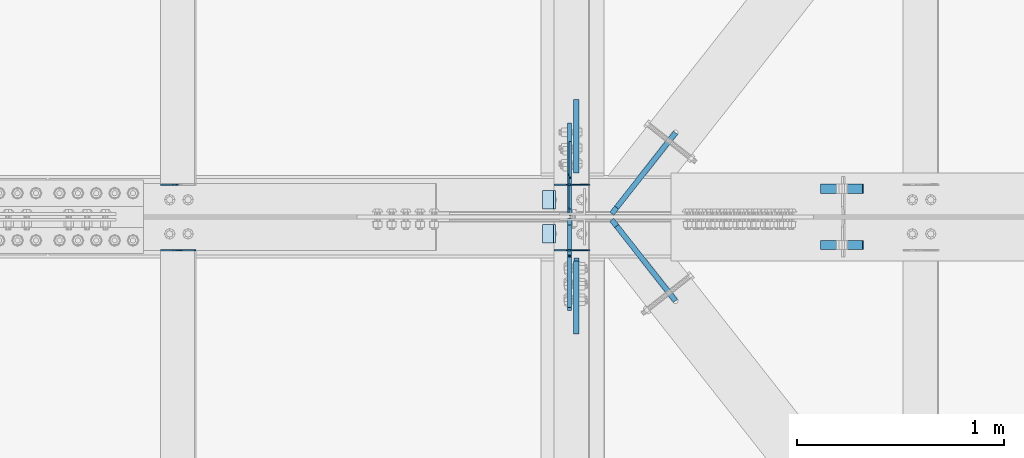
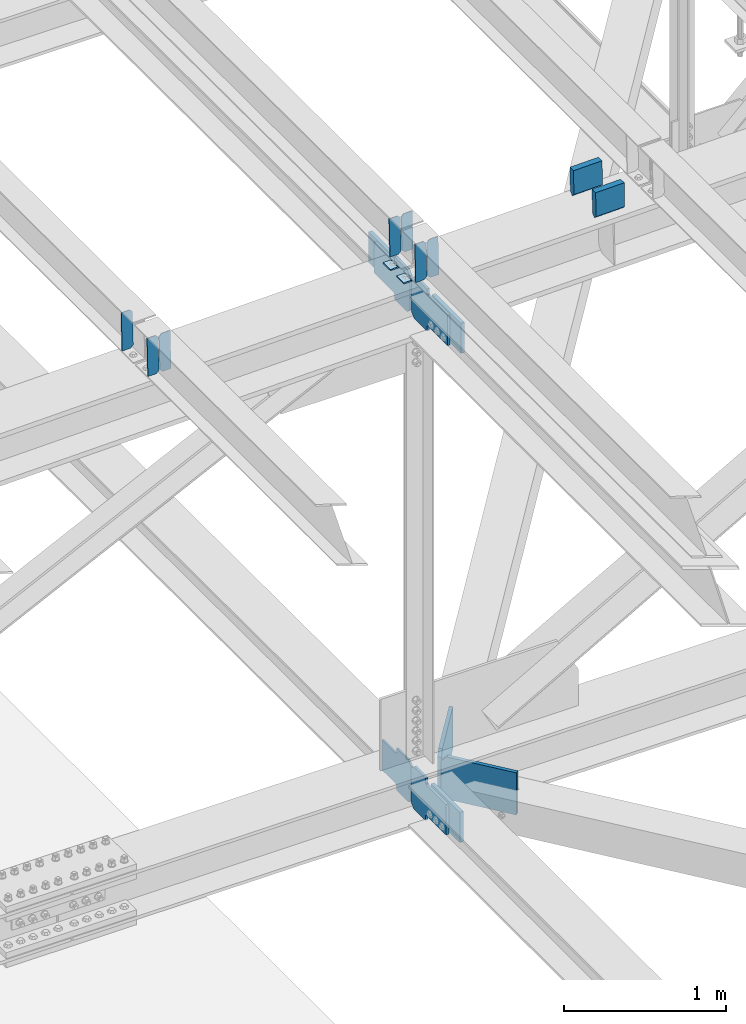
# One storey, part 3443 of 3843: 20 plates, 9 elements without a shape of their own.
"""IFC2X3 building model written with IfcOpenShell, lengths in millimetres."""

from ifc_helpers import new_model, si_unit, frame, origin_with_axes, place, context, subcontext, project, spatial, faceted_brep, material, type_object, element, aggregate, save


model = new_model("IFC2X3")

# Units and contexts
model_context = context("Model", 3, precision=1e-05, world=origin_with_axes())
body_context = subcontext(model_context, "Body", "Model", "MODEL_VIEW")
ifc_project = project(units=[si_unit("LENGTHUNIT", "METRE", prefix="MILLI"), si_unit("AREAUNIT", "SQUARE_METRE"), si_unit("VOLUMEUNIT", "CUBIC_METRE"), si_unit("MASSUNIT", "GRAM", prefix="KILO"), si_unit("TIMEUNIT", "SECOND"), si_unit("PLANEANGLEUNIT", "RADIAN"), si_unit("SOLIDANGLEUNIT", "STERADIAN"), si_unit("THERMODYNAMICTEMPERATUREUNIT", "DEGREE_CELSIUS"), si_unit("LUMINOUSINTENSITYUNIT", "LUMEN")], contexts=[model_context])

# Site, building, storey
site_placement = place(None, origin_with_axes())
site = spatial("IfcSite", under=ifc_project, at=site_placement, CompositionType="ELEMENT")
building_placement = place(site_placement, origin_with_axes())
building = spatial("IfcBuilding", under=site, at=building_placement, Name="Undefined", CompositionType="ELEMENT")
storey_placement = place(building_placement, origin_with_axes())
storey = spatial("IfcBuildingStorey", under=building, at=storey_placement, Name="Undefined", CompositionType="ELEMENT", Elevation=0.0)

# Assembly, plates
assembly_1_placement = place(storey_placement, origin_with_axes())
assembly_1 = element("IfcElementAssembly", 1, at=assembly_1_placement, inside=storey, Name="BEAM", AssemblyPlace="NOTDEFINED", PredefinedType="RIGID_FRAME")
ifc_material = material(Name="STEEL/A572-50")
plate_type_1 = type_object("IfcPlateType", PredefinedType="NOTDEFINED")
plate_1_placement = place(assembly_1_placement, frame((70338.6964783486, 67426.8505535728, 46241.0453819041), z_axis=(-0.0211520982737129, 0.00209111100100563, 0.999774082477337), x_axis=(-0.999776269341606, -4.42409999740035e-05, -0.0211520520071913)))
plate_1 = element("IfcPlate", 2, at=plate_1_placement, type_object=plate_type_1, material=ifc_material, Name="PLATE", context=body_context, shape_type="Brep", body=[
    faceted_brep([(0.0, -3.17499999999927, 0.0), (6.83940015733242e-10, -3.17499999996653, 288.924999998613), (6.54836185276508e-10, 3.17500000001746, 288.924999998591), (0.0, 3.17499999999927, 0.0), (60.3250007643655, -3.17500000017753, 288.924999998606), (60.3250007643219, 3.17499999979918, 288.924999998584), (79.3750000013097, -3.17500000025029, 269.875000761494), (79.375000001266, 3.17499999972642, 269.875000761487), (79.375000000713, -3.17500000026484, 19.0499992370605), (79.3750000006985, 3.17499999971187, 19.0499992370533), (60.325000763667, -3.17500000020664, -1.45519152283669e-11), (60.3250007636234, 3.17499999977736, -3.63797880709171e-11)], [[[0, 1, 2, 3]], [[1, 4, 5, 2]], [[4, 6, 7, 5]], [[6, 8, 9, 7]], [[8, 10, 11, 9]], [[10, 0, 3, 11]], [[5, 7, 9, 11, 3, 2]], [[10, 8, 6, 4, 1, 0]]]),
])
plate_2_placement = place(assembly_1_placement, frame((70252.9906576583, 67426.8467609886, 46239.2321222687), z_axis=(-0.0211520982737129, 0.00209111100100563, 0.999774082477337), x_axis=(-0.999776269341606, -4.42409999740035e-05, -0.0211520520071913)))
plate_2 = element("IfcPlate", 3, at=plate_2_placement, type_object=plate_type_1, material=ifc_material, Name="PLATE", context=body_context, shape_type="Brep", body=[
    faceted_brep([(4.36557456851006e-11, -3.17499999998836, 19.0499992370969), (6.11180439591408e-10, -3.17499999996653, 269.875000761516), (5.96628524363041e-10, 3.17500000001746, 269.875000761502), (1.45519152283669e-11, 3.17499999998836, 19.0499992370824), (19.0499992376572, -3.17500000003201, 288.924999998606), (19.0499992376281, 3.1749999999447, 288.924999998584), (79.3750000013242, -3.17500000025029, 288.924999998591), (79.3750000013097, 3.1749999997337, 288.92499999857), (79.3750000006548, -3.17500000026484, -2.18278728425503e-11), (79.3750000006403, 3.17499999969732, -2.91038304567337e-11), (19.0499992370023, -3.17500000005384, 0.0), (19.0499992369587, 3.17499999992287, -1.45519152283669e-11)], [[[0, 1, 2, 3]], [[1, 4, 5, 2]], [[4, 6, 7, 5]], [[6, 8, 9, 7]], [[8, 10, 11, 9]], [[10, 0, 3, 11]], [[5, 7, 9, 11, 3, 2]], [[10, 8, 6, 4, 1, 0]]]),
])

assembly_2_placement = place(storey_placement, origin_with_axes())
assembly_2 = element("IfcElementAssembly", 4, at=assembly_2_placement, inside=storey, Name="BEAM", AssemblyPlace="NOTDEFINED", PredefinedType="RIGID_FRAME")
plate_3_placement = place(assembly_2_placement, frame((70338.6964783569, 67109.8301249586, 46241.4481995165), z_axis=(-0.0211520985042007, 0.00048581000014383, 0.999776151304637), x_axis=(-0.999776269336729, -1.02780000340977e-05, -0.0211520960071139)))
plate_3 = element("IfcPlate", 5, at=plate_3_placement, type_object=plate_type_1, material=ifc_material, Name="PLATE", context=body_context, shape_type="Brep", body=[
    faceted_brep([(0.0, -3.17499999999927, 0.0), (6.83940015733242e-10, -3.17499999996653, 288.924999998613), (6.54836185276508e-10, 3.17500000001746, 288.924999998591), (0.0, 3.17499999999927, 0.0), (60.3250007643655, -3.17500000017753, 288.924999998606), (60.3250007643219, 3.17499999979918, 288.924999998584), (79.3750000013097, -3.17500000025029, 269.875000761494), (79.375000001266, 3.17499999972642, 269.875000761487), (79.375000000713, -3.17500000026484, 19.0499992370605), (79.3750000006985, 3.17499999971187, 19.0499992370533), (60.325000763667, -3.17500000020664, -1.45519152283669e-11), (60.3250007636234, 3.17499999977736, -3.63797880709171e-11)], [[[0, 1, 2, 3]], [[1, 4, 5, 2]], [[4, 6, 7, 5]], [[6, 8, 9, 7]], [[8, 10, 11, 9]], [[10, 0, 3, 11]], [[5, 7, 9, 11, 3, 2]], [[10, 8, 6, 4, 1, 0]]]),
])
plate_4_placement = place(assembly_2_placement, frame((70252.9906576667, 67109.8292438593, 46239.6349361285), z_axis=(-0.0211520985042007, 0.00048581000014383, 0.999776151304637), x_axis=(-0.999776269336729, -1.02780000340977e-05, -0.0211520960071139)))
plate_4 = element("IfcPlate", 6, at=plate_4_placement, type_object=plate_type_1, material=ifc_material, Name="PLATE", context=body_context, shape_type="Brep", body=[
    faceted_brep([(4.36557456851006e-11, -3.17499999998836, 19.0499992370969), (6.11180439591408e-10, -3.17499999996653, 269.875000761516), (5.96628524363041e-10, 3.17500000001746, 269.875000761502), (1.45519152283669e-11, 3.17499999998836, 19.0499992370824), (19.0499992376572, -3.17500000003201, 288.924999998606), (19.0499992376281, 3.1749999999447, 288.924999998584), (79.3750000013242, -3.17500000025029, 288.924999998591), (79.3750000013097, 3.1749999997337, 288.92499999857), (79.3750000006548, -3.17500000026484, -2.18278728425503e-11), (79.3750000006403, 3.17499999969732, -2.91038304567337e-11), (19.0499992370023, -3.17500000005384, 0.0), (19.0499992369587, 3.17499999992287, -1.45519152283669e-11)], [[[0, 1, 2, 3]], [[1, 4, 5, 2]], [[4, 6, 7, 5]], [[6, 8, 9, 7]], [[8, 10, 11, 9]], [[10, 0, 3, 11]], [[5, 7, 9, 11, 3, 2]], [[10, 8, 6, 4, 1, 0]]]),
])

# Assembly, plate
assembly_3_placement = place(storey_placement, origin_with_axes())
assembly_3 = element("IfcElementAssembly", 7, at=assembly_3_placement, inside=storey, Name="BEAM", AssemblyPlace="NOTDEFINED", PredefinedType="RIGID_FRAME")
plate_5_placement = place(assembly_3_placement, frame((68347.990842434, 67426.858871506, 46199.2681036841), z_axis=(-0.0211520984965173, 0.00205084399976477, 0.999774165883517), x_axis=(-0.999776269341419, -4.278700010456e-05, -0.0211520550071887)))
plate_5 = element("IfcPlate", 8, at=plate_5_placement, type_object=plate_type_1, material=ifc_material, Name="PLATE", context=body_context, shape_type="Brep", body=[
    faceted_brep([(4.36557456851006e-11, -3.17499999998836, 19.0499992370969), (6.11180439591408e-10, -3.17499999996653, 269.875000761516), (5.96628524363041e-10, 3.17500000001746, 269.875000761502), (1.45519152283669e-11, 3.17499999998836, 19.0499992370824), (19.0499992376572, -3.17500000003201, 288.924999998606), (19.0499992376281, 3.1749999999447, 288.924999998584), (79.3750000013242, -3.17500000025029, 288.924999998591), (79.3750000013097, 3.1749999997337, 288.92499999857), (79.3750000006548, -3.17500000026484, -2.18278728425503e-11), (79.3750000006403, 3.17499999969732, -2.91038304567337e-11), (19.0499992370023, -3.17500000005384, 0.0), (19.0499992369587, 3.17499999992287, -1.45519152283669e-11)], [[[0, 1, 2, 3]], [[1, 4, 5, 2]], [[4, 6, 7, 5]], [[6, 8, 9, 7]], [[8, 10, 11, 9]], [[10, 0, 3, 11]], [[5, 7, 9, 11, 3, 2]], [[10, 8, 6, 4, 1, 0]]]),
])
aggregate(assembly_3, [plate_5])

# Assembly, plates
assembly_4_placement = place(storey_placement, origin_with_axes())
assembly_4 = element("IfcElementAssembly", 9, at=assembly_4_placement, inside=storey, Name="BEAM", AssemblyPlace="NOTDEFINED", PredefinedType="RIGID_FRAME")
plate_6_placement = place(assembly_4_placement, frame((68433.6966586244, 67109.8415884794, 46201.4717238773), z_axis=(-0.0211520981150825, 0.000447354000119958, 0.999776169259764), x_axis=(-0.999776269336729, -1.02780000340977e-05, -0.0211520960071139)))
plate_6 = element("IfcPlate", 10, at=plate_6_placement, type_object=plate_type_1, material=ifc_material, Name="PLATE", context=body_context, shape_type="Brep", body=[
    faceted_brep([(0.0, -3.17499999999927, 0.0), (6.83940015733242e-10, -3.17499999996653, 288.924999998613), (6.54836185276508e-10, 3.17500000001746, 288.924999998591), (0.0, 3.17499999999927, 0.0), (60.3250007643655, -3.17500000017753, 288.924999998606), (60.3250007643219, 3.17499999979918, 288.924999998584), (79.3750000013097, -3.17500000025029, 269.875000761494), (79.375000001266, 3.17499999972642, 269.875000761487), (79.375000000713, -3.17500000026484, 19.0499992370605), (79.3750000006985, 3.17499999971187, 19.0499992370533), (60.325000763667, -3.17500000020664, -1.45519152283669e-11), (60.3250007636234, 3.17499999977736, -3.63797880709171e-11)], [[[0, 1, 2, 3]], [[1, 4, 5, 2]], [[4, 6, 7, 5]], [[6, 8, 9, 7]], [[8, 10, 11, 9]], [[10, 0, 3, 11]], [[5, 7, 9, 11, 3, 2]], [[10, 8, 6, 4, 1, 0]]]),
])
plate_7_placement = place(assembly_4_placement, frame((68347.9908379331, 67109.8407790113, 46199.6584604568), z_axis=(-0.0211520981150825, 0.000447354000119958, 0.999776169259764), x_axis=(-0.999776269336729, -1.02780000340977e-05, -0.0211520960071139)))
plate_7 = element("IfcPlate", 11, at=plate_7_placement, type_object=plate_type_1, material=ifc_material, Name="PLATE", context=body_context, shape_type="Brep", body=[
    faceted_brep([(4.36557456851006e-11, -3.17499999998836, 19.0499992370969), (6.11180439591408e-10, -3.17499999996653, 269.875000761516), (5.96628524363041e-10, 3.17500000001746, 269.875000761502), (1.45519152283669e-11, 3.17499999998836, 19.0499992370824), (19.0499992376572, -3.17500000003201, 288.924999998606), (19.0499992376281, 3.1749999999447, 288.924999998584), (79.3750000013242, -3.17500000025029, 288.924999998591), (79.3750000013097, 3.1749999997337, 288.92499999857), (79.3750000006548, -3.17500000026484, -2.18278728425503e-11), (79.3750000006403, 3.17499999969732, -2.91038304567337e-11), (19.0499992370023, -3.17500000005384, 0.0), (19.0499992369587, 3.17499999992287, -1.45519152283669e-11)], [[[0, 1, 2, 3]], [[1, 4, 5, 2]], [[4, 6, 7, 5]], [[6, 8, 9, 7]], [[8, 10, 11, 9]], [[10, 0, 3, 11]], [[5, 7, 9, 11, 3, 2]], [[10, 8, 6, 4, 1, 0]]]),
])
aggregate(assembly_4, [plate_6, plate_7])

assembly_5_placement = place(storey_placement, origin_with_axes())
assembly_5 = element("IfcElementAssembly", 12, at=assembly_5_placement, inside=storey, Name="BEAM", AssemblyPlace="NOTDEFINED", PredefinedType="RIGID_FRAME")
plate_type_2 = type_object("IfcPlateType", PredefinedType="NOTDEFINED")
plate_8_placement = place(assembly_5_placement, frame((71456.2169066286, 67408.028125, 46460.7259145974), z_axis=(0.0217666070074993, 0.0, -0.999763079343992), x_axis=(0.999763079343992, 0.0, 0.0217666070075027)))
plate_8 = element("IfcPlate", 13, at=plate_8_placement, type_object=plate_type_2, material=ifc_material, Name="PLATE", context=body_context, shape_type="Brep", body=[
    faceted_brep([(203.200005058941, -22.2250000000058, -1.16415321826935e-10), (7.27595761418343e-12, -22.2250000000058, -7.27595761418343e-12), (7.27595761418343e-12, 22.2250000000058, -7.27595761418343e-12), (203.200005058941, 22.2250000000058, -1.16415321826935e-10), (203.838531807472, -22.2250000000058, 0.00187068080413155), (203.838531807472, 22.2250000000058, 0.00187068080413155), (203.310341304641, -22.2250000000058, 180.861817383484), (0.04046799018397, -22.2250000000058, 180.907287948779), (203.245434494536, 0.0133131837355904, 203.086833080139), (0.0454396034692763, 0.0133129994646879, 203.132287829787), (0.0404679902494536, 22.2250000000058, 180.907288225317), (203.310341303353, 22.2250000000058, 180.861817822159)], [[[0, 1, 2, 3]], [[4, 0, 3, 5]], [[1, 0, 4, 6, 7]], [[7, 6, 8, 9]], [[2, 1, 7, 9, 10]], [[5, 3, 2, 10, 11]], [[6, 4, 5, 11, 8]], [[10, 9, 8, 11]]]),
])
plate_9_placement = place(assembly_5_placement, frame((71456.2169066286, 67134.978125, 46460.7259145974), z_axis=(0.0217666070074993, 0.0, -0.999763079343992), x_axis=(0.999763079343992, 0.0, 0.0217666070075027)))
plate_9 = element("IfcPlate", 14, at=plate_9_placement, type_object=plate_type_2, material=ifc_material, Name="PLATE", context=body_context, shape_type="Brep", body=[
    faceted_brep([(203.200005058941, -22.2250000000058, -1.16415321826935e-10), (7.27595761418343e-12, -22.2250000000058, -7.27595761418343e-12), (7.27595761418343e-12, 22.2250000000058, -7.27595761418343e-12), (203.200005058941, 22.2250000000058, -1.16415321826935e-10), (203.838531807472, -22.2250000000058, 0.00187068080413155), (203.838531807472, 22.2250000000058, 0.00187068080413155), (203.310341304641, -22.2250000000058, 180.861817383484), (0.04046799018397, -22.2250000000058, 180.907287948779), (203.245434494536, 0.0133131837355904, 203.086833080139), (0.0454396034692763, 0.0133129994646879, 203.132287829787), (0.0404679902494536, 22.2250000000058, 180.907288225317), (203.310341303353, 22.2250000000058, 180.861817822159)], [[[0, 1, 2, 3]], [[4, 0, 3, 5]], [[1, 0, 4, 6, 7]], [[7, 6, 8, 9]], [[2, 1, 7, 9, 10]], [[5, 3, 2, 10, 11]], [[6, 4, 5, 11, 8]], [[10, 9, 8, 11]]]),
])

# Plate
plate_type_3 = type_object("IfcPlateType", PredefinedType="NOTDEFINED")
plate_10_placement = place(assembly_1_placement, frame((70173.767725077, 67398.8999999999, 46231.5289989981), z_axis=(0.0, -1.0, 0.0), x_axis=(-0.999776270257024, 0.0, -0.0211520550054595)))
plate_10 = element("IfcPlate", 15, at=plate_10_placement, type_object=plate_type_3, material=ifc_material, Name="PLATE", context=body_context, shape_type="Brep", body=[
    faceted_brep([(9.52499999982683, -4.7625000001135, 88.8999999999942), (0.0, 4.76249999999709, 88.9000015258789), (0.0, 4.76249999999709, 0.0), (9.52499999981956, -4.76249999999709, 0.0), (63.4999984608512, -4.76249999988795, 88.8999999999796), (63.4999984608367, -4.76249999988795, -1.45519152283669e-11), (63.4999984608221, 4.76250000013533, -1.45519152283669e-11), (63.4999984608367, 4.76250000013533, 88.8999999999796)], [[[0, 1, 2, 3]], [[4, 5, 6, 7]], [[5, 4, 0, 3]], [[6, 5, 3, 2]], [[7, 6, 2, 1]], [[4, 7, 1, 0]]]),
])

aggregate(assembly_1, [plate_1, plate_2, plate_10])

plate_11_placement = place(assembly_2_placement, frame((70173.767725077, 67233.8000015258, 46231.5289989981), z_axis=(0.0, -1.0, 0.0), x_axis=(-0.999776270257024, 0.0, -0.0211520550054595)))
plate_11 = element("IfcPlate", 16, at=plate_11_placement, type_object=plate_type_3, material=ifc_material, Name="PLATE", context=body_context, shape_type="Brep", body=[
    faceted_brep([(9.52499999982683, -4.7625000001135, 88.8999999999942), (0.0, 4.76249999999709, 88.9000015258789), (0.0, 4.76249999999709, 0.0), (9.52499999981956, -4.76249999999709, 0.0), (63.4999984608512, -4.76249999988795, 88.8999999999796), (63.4999984608367, -4.76249999988795, -1.45519152283669e-11), (63.4999984608221, 4.76250000013533, -1.45519152283669e-11), (63.4999984608367, 4.76250000013533, 88.8999999999796)], [[[0, 1, 2, 3]], [[4, 5, 6, 7]], [[5, 4, 0, 3]], [[6, 5, 3, 2]], [[7, 6, 2, 1]], [[4, 7, 1, 0]]]),
])

aggregate(assembly_2, [plate_3, plate_4, plate_11])

# Assembly, plates
assembly_6_placement = place(storey_placement, origin_with_axes())
assembly_6 = element("IfcElementAssembly", 17, at=assembly_6_placement, inside=storey, Name="BEAM", AssemblyPlace="NOTDEFINED", PredefinedType="RIGID_FRAME")
plate_type_4 = type_object("IfcPlateType", PredefinedType="NOTDEFINED")
plate_12_placement = place(assembly_6_placement, frame((70245.28749986, 67279.0437469874, 42217.1730536663), z_axis=(0.0, 0.707106781186548, 0.707106781186548), x_axis=(5.70000238222118e-08, 0.707106781186546, -0.707106781186546)))
plate_12 = element("IfcPlate", 18, at=plate_12_placement, type_object=plate_type_4, material=ifc_material, Name="PLATE", context=body_context, shape_type="Brep", body=[
    faceted_brep([(0.0, -6.3499999046162, 0.0), (-179.602362598063, -6.35000000000582, 179.60236259806), (-179.602362598063, 6.35000000000582, 179.60236259806), (7.27595761418343e-12, 6.3499999046162, 0.0), (-179.602362597605, -6.35000000000582, 224.503643203658), (-179.602362597605, 6.35000000000582, 224.503643203658), (-75.7681511911323, -6.35000000000582, 328.33785461013), (-75.7681511911323, 6.35000000000582, 328.33785461013), (-52.9567776763506, -6.35000000000582, 305.526481095338), (-52.9567776763506, 6.35000000000582, 305.526481095338), (-48.836601208197, -6.35000000000582, 302.773467194886), (-48.836601208197, 6.35000000000582, 302.773467194886), (-43.9765216901433, -6.35000000000582, 301.806737272316), (-43.9765216901433, 6.35000000000582, 301.806737272316), (-39.116442172075, -6.35000000000582, 302.773467194929), (-39.116442172075, 6.35000000000582, 302.773467194929), (-34.9962657038996, -6.35000000000582, 305.52648109544), (-34.9962657038996, 6.35000000000582, 305.52648109544), (81.7470640018073, -6.35000000000582, 422.269810801154), (81.7470640018073, 6.35000000000582, 422.269810801154), (243.391674180282, -6.35000000000582, 260.625200622671), (243.391674180282, 6.35000000000582, 260.625200622671), (126.648344474575, -6.35000000000582, 143.881870916972), (126.648344474575, 6.35000000000582, 143.881870916972), (123.895330574065, -6.35000000000582, 139.761694448782), (123.895330574065, 6.35000000000582, 139.761694448782), (122.928600651452, -6.35000000000582, 134.901614930728), (122.928600651452, 6.35000000000582, 134.901614930728), (123.895330574022, -6.35000000000582, 130.041535412674), (123.895330574022, 6.35000000000582, 130.041535412674), (126.648344474481, -6.35000000000582, 125.921358944513), (126.648344474481, 6.35000000000582, 125.921358944513), (148.735492004496, -6.35000000000582, 103.834211399357), (148.735492004496, 6.35000000000582, 103.834211399357), (44.9012806051323, -6.35000000000582, -1.45519152283669e-11), (44.9012806051323, 6.35000000000582, -1.45519152283669e-11)], [[[0, 1, 2, 3]], [[1, 4, 5, 2]], [[4, 6, 7, 5]], [[6, 8, 9, 7]], [[8, 10, 11, 9]], [[10, 12, 13, 11]], [[12, 14, 15, 13]], [[14, 16, 17, 15]], [[16, 18, 19, 17]], [[18, 20, 21, 19]], [[20, 22, 23, 21]], [[22, 24, 25, 23]], [[24, 26, 27, 25]], [[26, 28, 29, 27]], [[28, 30, 31, 29]], [[30, 32, 33, 31]], [[32, 34, 35, 33]], [[34, 0, 3, 35]], [[5, 7, 9, 11, 13, 15, 17, 19, 21, 23, 25, 27, 29, 31, 33, 35, 3, 2]], [[34, 32, 30, 28, 26, 24, 22, 20, 18, 16, 14, 12, 10, 8, 6, 4, 1, 0]]]),
])
plate_type_5 = type_object("IfcPlateType", PredefinedType="NOTDEFINED")
plate_13_placement = place(assembly_6_placement, frame((70240.5250905931, 67264.7562469837, 42217.1756375467), z_axis=(0.0, -0.707106781186682, 0.707106781186413), x_axis=(0.0, -0.707106781186548, -0.707106781186548)))
plate_13 = element("IfcPlate", 19, at=plate_13_placement, type_object=plate_type_5, material=ifc_material, Name="PLATE", context=body_context, shape_type="Brep", body=[
    faceted_brep([(0.0, -9.52500000000146, 0.0), (-179.60097790591, -9.52499999999418, 179.60097790587), (-179.60097790591, 9.52499999999418, 179.60097790587), (0.0, 9.52500000000146, 0.0), (-179.600977905429, -9.52499999999418, 224.50225851146), (-179.600977905429, 9.52499999999418, 224.50225851146), (-75.7667665073968, -9.52499999999418, 328.336469909522), (-75.7667665073968, 9.52499999999418, 328.336469909522), (-53.3967288171552, -9.52499999999418, 305.966432219277), (-53.3967288171552, 9.52499999999418, 305.966432219277), (-49.2765523490089, -9.52499999999418, 303.21341831881), (-49.2765523490089, 9.52499999999418, 303.21341831881), (-44.4164728309552, -9.52499999999418, 302.246688396241), (-44.4164728309552, 9.52499999999418, 302.246688396241), (-39.5563933128869, -9.52499999999418, 303.213418318857), (-39.5563933128869, 9.52499999999418, 303.213418318857), (-35.4362168447115, -9.52499999999418, 305.966432219364), (-35.4362168447115, 9.52499999999418, 305.966432219364), (135.188649583215, -9.52499999999418, 476.591298647309), (135.188649583215, 9.52499999999418, 476.591298647309), (296.833259761697, -9.52499999999418, 314.946688468866), (296.833259761697, 9.52499999999418, 314.946688468866), (126.208393333785, -9.52499999999418, 144.321822040918), (126.208393333785, 9.52499999999418, 144.321822040918), (123.45537943329, -9.52499999999418, 140.201645572739), (123.45537943329, 9.52499999999418, 140.201645572739), (122.488649510662, -9.52499999999418, 135.341566054674), (122.488649510662, 9.52499999999418, 135.341566054674), (123.455379433231, -9.52499999999418, 130.481486536624), (123.455379433231, 9.52499999999418, 130.481486536624), (126.208393333698, -9.52499999999418, 126.361310068467), (126.208393333698, 9.52499999999418, 126.361310068467), (148.735492003645, -9.52499999999418, 103.834211398527), (148.735492003645, 9.52499999999418, 103.834211398527), (44.9012806055835, -9.52499999999418, 4.65661287307739e-10), (44.9012806055835, 9.52499999999418, 4.65661287307739e-10)], [[[0, 1, 2, 3]], [[1, 4, 5, 2]], [[4, 6, 7, 5]], [[6, 8, 9, 7]], [[8, 10, 11, 9]], [[10, 12, 13, 11]], [[12, 14, 15, 13]], [[14, 16, 17, 15]], [[16, 18, 19, 17]], [[18, 20, 21, 19]], [[20, 22, 23, 21]], [[22, 24, 25, 23]], [[24, 26, 27, 25]], [[26, 28, 29, 27]], [[28, 30, 31, 29]], [[30, 32, 33, 31]], [[32, 34, 35, 33]], [[34, 0, 3, 35]], [[5, 7, 9, 11, 13, 15, 17, 19, 21, 23, 25, 27, 29, 31, 33, 35, 3, 2]], [[34, 32, 30, 28, 26, 24, 22, 20, 18, 16, 14, 12, 10, 8, 6, 4, 1, 0]]]),
])

# Plate
plate_14_placement = place(assembly_5_placement, frame((70242.1124997146, 67283.0125000015, 45904.4880019232), z_axis=(0.0, 0.707106781186548, 0.707106781186548), x_axis=(5.70000238222118e-08, 0.707106781186546, -0.707106781186546)))
plate_14 = element("IfcPlate", 20, at=plate_14_placement, type_object=plate_type_5, material=ifc_material, Name="PLATE", context=body_context, shape_type="Brep", body=[
    faceted_brep([(0.0, -9.52500000000146, 0.0), (-179.373306890528, -9.52499999999418, 179.373306890833), (-179.373306890528, 9.52499999999418, 179.373306890833), (0.0, 9.52500000000146, 0.0), (-179.37330689048, -9.52499999999418, 224.274587496446), (-179.37330689048, 9.52499999999418, 224.274587496446), (-68.2426373894159, -9.52499999999418, 335.405256998449), (-68.2426373894159, 9.52499999999418, 335.405256998449), (-45.7376059398557, -9.52499999999418, 312.900225548845), (-45.7376059398557, 9.52499999999418, 312.900225548845), (-41.6174294716911, -9.52499999999418, 310.147211648378), (-41.6174294716911, 9.52499999999418, 310.147211648378), (-36.7573499536229, -9.52499999999418, 309.180481725809), (-36.7573499536229, 9.52499999999418, 309.180481725809), (-31.8972704355438, -9.52499999999418, 310.147211648451), (-31.8972704355438, 9.52499999999418, 310.147211648451), (-27.7770939673683, -9.52499999999418, 312.900225548961), (-27.7770939673683, 9.52499999999418, 312.900225548961), (142.847772465273, -9.52499999999418, 483.525091983043), (142.847772465273, 9.52499999999418, 483.525091983043), (304.492382644421, -9.52499999999418, 321.88048180363), (304.492382644421, 9.52499999999418, 321.88048180363), (133.8675162117, -9.52499999999418, 151.255615369431), (133.8675162117, 9.52499999999418, 151.255615369431), (131.114502311208, -9.52499999999418, 147.135438901256), (131.114502311208, 9.52499999999418, 147.135438901256), (130.147772388616, -9.52499999999418, 142.275359383217), (130.147772388616, 9.52499999999418, 142.275359383217), (131.114502311175, -9.52499999999418, 137.415279865163), (131.114502311175, 9.52499999999418, 137.415279865163), (133.867516211638, -9.52499999999418, 133.295103397031), (133.867516211638, 9.52499999999418, 133.295103397031), (156.031950102854, -9.52499999999418, 111.130669497732), (156.031950102854, 9.52499999999418, 111.130669497732), (44.9012806055835, -9.52499999999418, 4.65661287307739e-10), (44.9012806055835, 9.52499999999418, 4.65661287307739e-10)], [[[0, 1, 2, 3]], [[1, 4, 5, 2]], [[4, 6, 7, 5]], [[6, 8, 9, 7]], [[8, 10, 11, 9]], [[10, 12, 13, 11]], [[12, 14, 15, 13]], [[14, 16, 17, 15]], [[16, 18, 19, 17]], [[18, 20, 21, 19]], [[20, 22, 23, 21]], [[22, 24, 25, 23]], [[24, 26, 27, 25]], [[26, 28, 29, 27]], [[28, 30, 31, 29]], [[30, 32, 33, 31]], [[32, 34, 35, 33]], [[34, 0, 3, 35]], [[5, 7, 9, 11, 13, 15, 17, 19, 21, 23, 25, 27, 29, 31, 33, 35, 3, 2]], [[34, 32, 30, 28, 26, 24, 22, 20, 18, 16, 14, 12, 10, 8, 6, 4, 1, 0]]]),
])

plate_15_placement = place(assembly_5_placement, frame((70242.1125702131, 67260.7874999709, 45904.4880032746), z_axis=(0.0, -0.707106781186682, 0.707106781186413), x_axis=(0.0, -0.707106781186548, -0.707106781186548)))
plate_15 = element("IfcPlate", 21, at=plate_15_placement, type_object=plate_type_5, material=ifc_material, Name="PLATE", context=body_context, shape_type="Brep", body=[
    faceted_brep([(0.0, -9.52500000000146, 0.0), (-179.373306890528, -9.52499999999418, 179.373306890833), (-179.373306890528, 9.52499999999418, 179.373306890833), (0.0, 9.52500000000146, 0.0), (-179.37330689048, -9.52499999999418, 224.274587496446), (-179.37330689048, 9.52499999999418, 224.274587496446), (-68.2426373894159, -9.52499999999418, 335.405256998449), (-68.2426373894159, 9.52499999999418, 335.405256998449), (-46.2059764698352, -9.52499999999418, 313.368596034767), (-46.2059764698352, 9.52499999999418, 313.368596034767), (-42.0858000016888, -9.52499999999418, 310.6155821343), (-42.0858000016888, 9.52499999999418, 310.6155821343), (-37.2257204836351, -9.52499999999418, 309.648852211738), (-37.2257204836351, 9.52499999999418, 309.648852211738), (-32.3656409655669, -9.52499999999418, 310.615582134358), (-32.3656409655669, 9.52499999999418, 310.615582134358), (-28.2454644973914, -9.52499999999418, 313.368596034858), (-28.2454644973914, 9.52499999999418, 313.368596034858), (142.379401961094, -9.52499999999418, 483.993462493343), (142.379401961094, 9.52499999999418, 483.993462493343), (304.024012139562, -9.52499999999418, 322.348852314872), (304.024012139562, 9.52499999999418, 322.348852314872), (133.399145681076, -9.52499999999418, 151.723985856386), (133.399145681076, 9.52499999999418, 151.723985856386), (130.646131780581, -9.52499999999418, 147.603809388214), (130.646131780581, 9.52499999999418, 147.603809388214), (129.679401857953, -9.52499999999418, 142.743729870142), (129.679401857953, 9.52499999999418, 142.743729870142), (130.646131780522, -9.52499999999418, 137.883650352089), (130.646131780522, 9.52499999999418, 137.883650352089), (133.399145680989, -9.52499999999418, 133.763473883942), (133.399145680989, 9.52499999999418, 133.763473883942), (156.031950102854, -9.52499999999418, 111.130669497732), (156.031950102854, 9.52499999999418, 111.130669497732), (44.9012806055835, -9.52499999999418, 4.65661287307739e-10), (44.9012806055835, 9.52499999999418, 4.65661287307739e-10)], [[[0, 1, 2, 3]], [[1, 4, 5, 2]], [[4, 6, 7, 5]], [[6, 8, 9, 7]], [[8, 10, 11, 9]], [[10, 12, 13, 11]], [[12, 14, 15, 13]], [[14, 16, 17, 15]], [[16, 18, 19, 17]], [[18, 20, 21, 19]], [[20, 22, 23, 21]], [[22, 24, 25, 23]], [[24, 26, 27, 25]], [[26, 28, 29, 27]], [[28, 30, 31, 29]], [[30, 32, 33, 31]], [[32, 34, 35, 33]], [[34, 0, 3, 35]], [[5, 7, 9, 11, 13, 15, 17, 19, 21, 23, 25, 27, 29, 31, 33, 35, 3, 2]], [[34, 32, 30, 28, 26, 24, 22, 20, 18, 16, 14, 12, 10, 8, 6, 4, 1, 0]]]),
])

aggregate(assembly_5, [plate_8, plate_9, plate_14, plate_15])

# Assembly, plate
assembly_7_placement = place(storey_placement, origin_with_axes())
assembly_7 = element("IfcElementAssembly", 22, at=assembly_7_placement, inside=storey, Name="BEAM", AssemblyPlace="NOTDEFINED", PredefinedType="RIGID_FRAME")
plate_type_6 = type_object("IfcPlateType", PredefinedType="NOTDEFINED")
plate_16_placement = place(assembly_7_placement, frame((70273.8624914684, 66703.5750001911, 45917.4456220324), z_axis=(0.0, 1.0, 0.0), x_axis=(0.0, 0.0, 1.0)))
plate_16 = element("IfcPlate", 23, at=plate_16_placement, type_object=plate_type_6, material=ifc_material, Name="PLATE", context=body_context, shape_type="Brep", body=[
    faceted_brep([(0.0, -12.6999999999971, 0.0), (0.0147141397246742, -12.7000000013795, 355.599999695551), (0.0147141397246742, 12.6999999986292, 355.599999695653), (0.0, 12.6999999999971, 0.0), (228.599998464349, -12.7000000013795, 355.599999691767), (228.599998464349, 12.6999999986292, 355.599999691869), (228.585197689645, -12.6999999999825, -2.18278728425503e-10), (228.585197689645, 12.7000000000116, -1.16415321826935e-10)], [[[0, 1, 2, 3]], [[1, 4, 5, 2]], [[4, 6, 7, 5]], [[6, 0, 3, 7]], [[5, 7, 3, 2]], [[6, 4, 1, 0]]]),
])
aggregate(assembly_7, [plate_16])

assembly_8_placement = place(storey_placement, origin_with_axes())
assembly_8 = element("IfcElementAssembly", 24, at=assembly_8_placement, inside=storey, Name="BEAM", AssemblyPlace="NOTDEFINED", PredefinedType="RIGID_FRAME")
plate_17_placement = place(assembly_8_placement, frame((70273.8624914684, 67484.6249996931, 45916.768530617), z_axis=(0.0, 1.0, 0.0), x_axis=(0.0, 0.0, 1.0)))
plate_17 = element("IfcPlate", 25, at=plate_17_placement, type_object=plate_type_6, material=ifc_material, Name="PLATE", context=body_context, shape_type="Brep", body=[
    faceted_brep([(0.0, -12.6999999999971, 0.0), (0.0147141397246742, -12.7000000013795, 355.599999695551), (0.0147141397246742, 12.6999999986292, 355.599999695653), (0.0, 12.6999999999971, 0.0), (228.629514935208, -12.7000000013795, 355.599999692029), (228.629514935208, 12.6999999986292, 355.599999692131), (228.614714160503, -12.6999999999971, 4.36557456851006e-11), (228.614714160503, 12.6999999999971, 1.45519152283669e-10)], [[[0, 1, 2, 3]], [[1, 4, 5, 2]], [[4, 6, 7, 5]], [[6, 0, 3, 7]], [[5, 7, 3, 2]], [[6, 4, 1, 0]]]),
])
aggregate(assembly_8, [plate_17])

assembly_9_placement = place(storey_placement, origin_with_axes())
assembly_9 = element("IfcElementAssembly", 26, at=assembly_9_placement, inside=storey, Name="BEAM", AssemblyPlace="NOTDEFINED", PredefinedType="RIGID_FRAME")
plate_18_placement = place(assembly_9_placement, frame((70275.4501501836, 67073.46200106, 42458.5831485102), z_axis=(0.0, 0.0, -1.0), x_axis=(0.0, -1.0, 0.0)))
plate_18 = element("IfcPlate", 27, at=plate_18_placement, type_object=plate_type_6, material=ifc_material, Name="PLATE", context=body_context, shape_type="Brep", body=[
    faceted_brep([(0.0, -12.6999999999971, 0.0), (1.30967237055302e-10, -12.6999999999971, 228.600000023711), (1.30967237055302e-10, 12.6999999999971, 228.600000023711), (0.0, 12.6999999999971, 0.0), (355.600000000137, -12.6999999999971, 228.600000023711), (355.600000000137, 12.6999999999971, 228.600000023711), (355.599999999999, -12.7000000000007, 0.0), (355.599999999999, 12.7000000000007, 0.0)], [[[0, 1, 2, 3]], [[1, 4, 5, 2]], [[4, 6, 7, 5]], [[6, 0, 3, 7]], [[5, 7, 3, 2]], [[6, 4, 1, 0]]]),
])
aggregate(assembly_9, [plate_18])

# Plate
plate_type_7 = type_object("IfcPlateType", PredefinedType="NOTDEFINED")
plate_19_placement = place(assembly_6_placement, frame((70446.0080861119, 67256.9005400319, 42185.3534629505), z_axis=(0.0, 0.0, 1.0), x_axis=(0.618559605792669, -0.78573787873668, 0.0)))
plate_19 = element("IfcPlate", 28, at=plate_19_placement, type_object=plate_type_7, material=ifc_material, Name="STIFFENER", context=body_context, shape_type="Brep", body=[
    faceted_brep([(0.0, -12.6999999999971, 38.0999999999913), (1.57808244694024e-07, -12.7000000000698, 279.400255757311), (1.5777550288476e-07, 12.6999999998807, 279.400255757319), (0.0, 12.6999999999971, 38.0999999999913), (38.0999986533716, -12.7000000000262, 317.500254231185), (38.0999986533352, 12.6999999999243, 317.500254231192), (498.707196532559, -12.7000000008702, 317.500253911428), (498.707196532486, 12.6999999989785, 317.500253911428), (498.707196286233, -12.7000000007829, 2.51748133450747e-09), (498.707196286153, 12.6999999990658, 2.51748133450747e-09), (239.994311326555, -12.7000000003463, 6.83940015733242e-10), (239.994311326475, 12.6999999995023, 6.83940015733242e-10), (38.1000000000058, -12.7000000000844, 2.18278728425503e-11), (38.1000000000058, 12.7000000000262, 4.36557456851006e-11)], [[[0, 1, 2, 3]], [[1, 4, 5, 2]], [[4, 6, 7, 5]], [[6, 8, 9, 7]], [[8, 10, 11, 9]], [[10, 12, 13, 11]], [[12, 0, 3, 13]], [[5, 7, 9, 11, 13, 3, 2]], [[12, 10, 8, 6, 4, 1, 0]]]),
])

plate_20_placement = place(assembly_6_placement, frame((70446.0080802216, 67286.8994540148, 42185.3534629505), z_axis=(0.0, 0.0, 1.0), x_axis=(0.618559606278724, 0.785737878354041, 0.0)))
plate_20 = element("IfcPlate", 29, at=plate_20_placement, type_object=plate_type_7, material=ifc_material, Name="STIFFENER", context=body_context, shape_type="Brep", body=[
    faceted_brep([(0.0, -12.6999999999971, 38.0999999999913), (1.57808244694024e-07, -12.7000000000698, 279.400255757311), (1.5777550288476e-07, 12.6999999998807, 279.400255757319), (0.0, 12.6999999999971, 38.0999999999913), (38.0999986533716, -12.7000000000262, 317.500254231185), (38.0999986533352, 12.6999999999243, 317.500254231192), (498.707196532559, -12.7000000008702, 317.500253911428), (498.707196532486, 12.6999999989785, 317.500253911428), (498.707196286233, -12.7000000007829, 2.51748133450747e-09), (498.707196286153, 12.6999999990658, 2.51748133450747e-09), (239.994311326555, -12.7000000003463, 6.83940015733242e-10), (239.994311326475, 12.6999999995023, 6.83940015733242e-10), (38.1000000000058, -12.7000000000844, 2.18278728425503e-11), (38.1000000000058, 12.7000000000262, 4.36557456851006e-11)], [[[0, 1, 2, 3]], [[1, 4, 5, 2]], [[4, 6, 7, 5]], [[6, 8, 9, 7]], [[8, 10, 11, 9]], [[10, 12, 13, 11]], [[12, 0, 3, 13]], [[5, 7, 9, 11, 13, 3, 2]], [[12, 10, 8, 6, 4, 1, 0]]]),
])

aggregate(assembly_6, [plate_12, plate_13, plate_19, plate_20])

save(model, "model.ifc")
